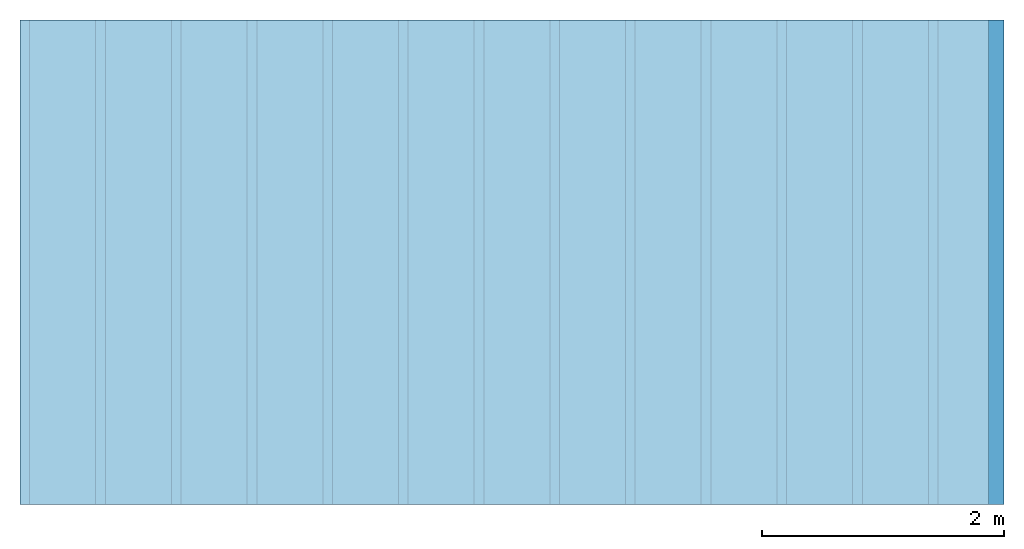
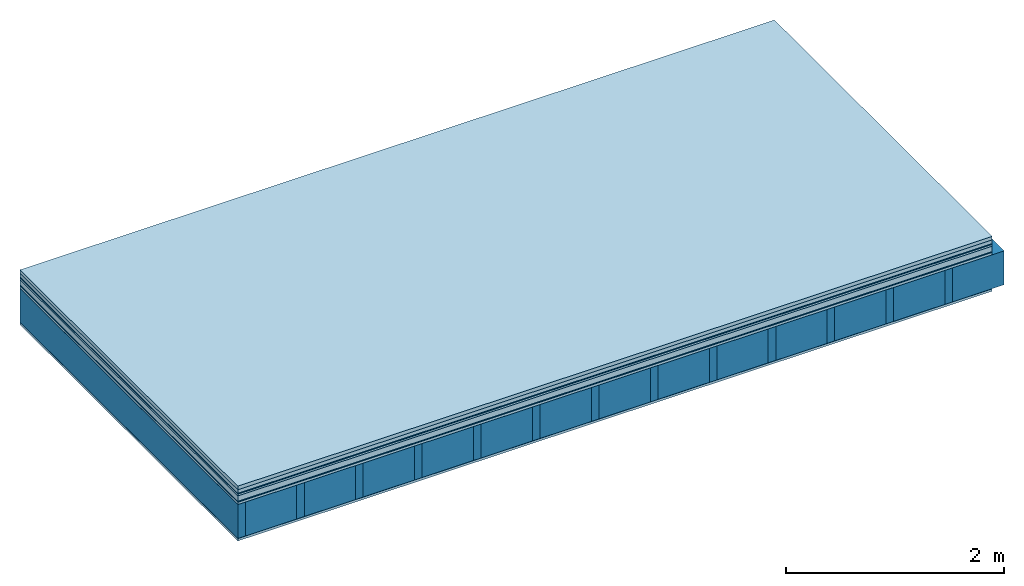
# One storey: 9 plates, 2 members, 1 element without a shape of its own.
"""IFC4 building model written with IfcOpenShell, lengths in metres."""

from ifc_helpers import new_model, si_unit, derived_unit, direction, frame, frame_2d, origin, origin_with_axes, place, context, project, spatial, rectangle, extrude, material, layer, layer_set, type_object, element, aggregate, save


model = new_model("IFC4")

# Units and contexts
plan_context = context("Plan", 3, precision=1e-05, world=origin(), true_north=direction((0.0, 1.0)))
model_context = context("Model", 3, precision=1e-05, world=origin(), true_north=direction((0.0, 1.0)))
ifc_project = project(units=[si_unit("LENGTHUNIT", "METRE"), derived_unit("SOUNDPRESSUREUNIT", [(si_unit("PRESSUREUNIT", "PASCAL", prefix="MICRO"), 0)]), si_unit("ENERGYUNIT", "JOULE", prefix="MEGA"), si_unit("MASSUNIT", "GRAM", prefix="KILO"), derived_unit("THERMALTRANSMITTANCEUNIT", [(si_unit("POWERUNIT", "WATT"), 1), (si_unit("AREAUNIT", "SQUARE_METRE"), -1), (si_unit("THERMODYNAMICTEMPERATUREUNIT", "KELVIN"), -1)]), derived_unit("AREADENSITYUNIT", [(si_unit("MASSUNIT", "GRAM", prefix="KILO"), 1), (si_unit("AREAUNIT", "SQUARE_METRE"), -1)]), derived_unit("USERDEFINED", [(si_unit("ENERGYUNIT", "JOULE", prefix="MEGA"), 1), (si_unit("AREAUNIT", "SQUARE_METRE"), -1)])], contexts=[plan_context, model_context])

# Site, building, storey
site = spatial("IfcSite", under=ifc_project)
building_placement = place(None, origin())
building = spatial("IfcBuilding", under=site, at=building_placement)
storey_placement = place(building_placement, origin())
storey = spatial("IfcBuildingStorey", under=building, at=storey_placement)

# Slab, members, plates
ifc_material_1 = material(Name="Garden plates", Category="02.007")
ifc_layer_1 = layer(ifc_material_1, 0.04, Name="Use and protection layer 3")
ifc_material_2 = material(Name="Gravel 8-16mm", Category="03.011")
ifc_layer_2 = layer(ifc_material_2, 0.04, Name="Use and protection layer 2")
ifc_material_3 = material(Name="Protective layer", Category="09.007")
ifc_layer_3 = layer(ifc_material_3, 0.01, Name="Use and protection layer 1")
ifc_material_4 = material(Name="Bituminous", Category="09.003")
ifc_layer_4 = layer(ifc_material_4, 0.02, Name="Seal")
ifc_material_5 = material(Name="Mineral wool", Category="10.008")
ifc_layer_5 = layer(ifc_material_5, 0.06, Name="Exterior insulation layer 1")
ifc_material_6 = material(Name="Vapor-permeable barrier", Category="09.006")
ifc_layer_6 = layer(ifc_material_6, 0.01, Name="layer / temporary roof")
ifc_material_7 = material(Name="3-layer panels", Category="07.001")
ifc_layer_7 = layer(ifc_material_7, 0.027, Name="above 2nd layer")
ifc_material_8 = material(Name="no composite action")
ifc_layer_8 = layer(ifc_material_8, 0.0, Name="Bond")
ifc_layer_9 = layer(None, 0.38, Name="Support")
ifc_material_9 = material(Name="of the art")
ifc_layer_10 = layer(ifc_material_9, 0.0, Name="Bond")
ifc_material_10 = material(Name="Vapor barrier polyethylene (PE)", Category="09.002")
ifc_layer_11 = layer(ifc_material_10, 0.001, Name="Vapor barrier")
ifc_layer_12 = layer(ifc_material_7, 0.027, Name="Covering below 1st layer")
ifc_layer_set = layer_set([ifc_layer_1, ifc_layer_2, ifc_layer_3, ifc_layer_4, ifc_layer_5, ifc_layer_6, ifc_layer_7, ifc_layer_8, ifc_layer_9, ifc_layer_10, ifc_layer_11, ifc_layer_12])
slab_type = type_object("IfcSlabType", Name="F0105", PredefinedType="NOTDEFINED", material=ifc_layer_set)
slab_placement = place(None, frame((0.0, 0.0, 0.0), z_axis=(0.0, 0.0, -1.0), x_axis=(1.0, 0.0, 0.0)))
slab = element("IfcSlab", 1, at=slab_placement, inside=storey, type_object=slab_type, material=ifc_layer_set, Name="Slab #1")
ifc_material_11 = material()
member_1_placement = place(slab_placement, origin())
member_1 = element("IfcMember", 2, at=member_1_placement, material=ifc_material_11, Name="Support", context=plan_context, shape_type="SweptSolid", body=[
    extrude(rectangle(XDim=0.08, YDim=0.38, at=frame_2d((0.04, 0.19), x_axis=(1.0, 0.0))), frame((0.0, 4.0, 0.207), z_axis=(0.0, -1.0, 0.0), x_axis=(1.0, 0.0, 0.0)), (0.0, 0.0, 1.0), 4.0),
    extrude(rectangle(XDim=0.08, YDim=0.38, at=frame_2d((0.04, 0.19), x_axis=(1.0, 0.0))), frame((0.625, 4.0, 0.207), z_axis=(0.0, -1.0, 0.0), x_axis=(1.0, 0.0, 0.0)), (0.0, 0.0, 1.0), 4.0),
    extrude(rectangle(XDim=0.08, YDim=0.38, at=frame_2d((0.04, 0.19), x_axis=(1.0, 0.0))), frame((1.25, 4.0, 0.207), z_axis=(0.0, -1.0, 0.0), x_axis=(1.0, 0.0, 0.0)), (0.0, 0.0, 1.0), 4.0),
    extrude(rectangle(XDim=0.08, YDim=0.38, at=frame_2d((0.04, 0.19), x_axis=(1.0, 0.0))), frame((1.875, 4.0, 0.207), z_axis=(0.0, -1.0, 0.0), x_axis=(1.0, 0.0, 0.0)), (0.0, 0.0, 1.0), 4.0),
    extrude(rectangle(XDim=0.08, YDim=0.38, at=frame_2d((0.04, 0.19), x_axis=(1.0, 0.0))), frame((2.5, 4.0, 0.207), z_axis=(0.0, -1.0, 0.0), x_axis=(1.0, 0.0, 0.0)), (0.0, 0.0, 1.0), 4.0),
    extrude(rectangle(XDim=0.08, YDim=0.38, at=frame_2d((0.04, 0.19), x_axis=(1.0, 0.0))), frame((3.125, 4.0, 0.207), z_axis=(0.0, -1.0, 0.0), x_axis=(1.0, 0.0, 0.0)), (0.0, 0.0, 1.0), 4.0),
    extrude(rectangle(XDim=0.08, YDim=0.38, at=frame_2d((0.04, 0.19), x_axis=(1.0, 0.0))), frame((3.75, 4.0, 0.207), z_axis=(0.0, -1.0, 0.0), x_axis=(1.0, 0.0, 0.0)), (0.0, 0.0, 1.0), 4.0),
    extrude(rectangle(XDim=0.08, YDim=0.38, at=frame_2d((0.04, 0.19), x_axis=(1.0, 0.0))), frame((4.375, 4.0, 0.207), z_axis=(0.0, -1.0, 0.0), x_axis=(1.0, 0.0, 0.0)), (0.0, 0.0, 1.0), 4.0),
    extrude(rectangle(XDim=0.08, YDim=0.38, at=frame_2d((0.04, 0.19), x_axis=(1.0, 0.0))), frame((5.0, 4.0, 0.207), z_axis=(0.0, -1.0, 0.0), x_axis=(1.0, 0.0, 0.0)), (0.0, 0.0, 1.0), 4.0),
    extrude(rectangle(XDim=0.08, YDim=0.38, at=frame_2d((0.04, 0.19), x_axis=(1.0, 0.0))), frame((5.625, 4.0, 0.207), z_axis=(0.0, -1.0, 0.0), x_axis=(1.0, 0.0, 0.0)), (0.0, 0.0, 1.0), 4.0),
    extrude(rectangle(XDim=0.08, YDim=0.38, at=frame_2d((0.04, 0.19), x_axis=(1.0, 0.0))), frame((6.25, 4.0, 0.207), z_axis=(0.0, -1.0, 0.0), x_axis=(1.0, 0.0, 0.0)), (0.0, 0.0, 1.0), 4.0),
    extrude(rectangle(XDim=0.08, YDim=0.38, at=frame_2d((0.04, 0.19), x_axis=(1.0, 0.0))), frame((6.875, 4.0, 0.207), z_axis=(0.0, -1.0, 0.0), x_axis=(1.0, 0.0, 0.0)), (0.0, 0.0, 1.0), 4.0),
    extrude(rectangle(XDim=0.08, YDim=0.38, at=frame_2d((0.04, 0.19), x_axis=(1.0, 0.0))), frame((7.5, 4.0, 0.207), z_axis=(0.0, -1.0, 0.0), x_axis=(1.0, 0.0, 0.0)), (0.0, 0.0, 1.0), 4.0),
])
ifc_material_12 = material()
member_2_placement = place(slab_placement, origin())
member_2 = element("IfcMember", 3, at=member_2_placement, material=ifc_material_12, Name="Cavity", context=plan_context, shape_type="SweptSolid", body=[
    extrude(rectangle(XDim=0.545, YDim=0.38, at=frame_2d((0.2725, 0.19), x_axis=(1.0, 0.0))), frame((0.08, 4.0, 0.207), z_axis=(0.0, -1.0, 0.0), x_axis=(1.0, 0.0, 0.0)), (0.0, 0.0, 1.0), 4.0),
    extrude(rectangle(XDim=0.545, YDim=0.38, at=frame_2d((0.2725, 0.19), x_axis=(1.0, 0.0))), frame((0.705, 4.0, 0.207), z_axis=(0.0, -1.0, 0.0), x_axis=(1.0, 0.0, 0.0)), (0.0, 0.0, 1.0), 4.0),
    extrude(rectangle(XDim=0.545, YDim=0.38, at=frame_2d((0.2725, 0.19), x_axis=(1.0, 0.0))), frame((1.33, 4.0, 0.207), z_axis=(0.0, -1.0, 0.0), x_axis=(1.0, 0.0, 0.0)), (0.0, 0.0, 1.0), 4.0),
    extrude(rectangle(XDim=0.545, YDim=0.38, at=frame_2d((0.2725, 0.19), x_axis=(1.0, 0.0))), frame((1.955, 4.0, 0.207), z_axis=(0.0, -1.0, 0.0), x_axis=(1.0, 0.0, 0.0)), (0.0, 0.0, 1.0), 4.0),
    extrude(rectangle(XDim=0.545, YDim=0.38, at=frame_2d((0.2725, 0.19), x_axis=(1.0, 0.0))), frame((2.58, 4.0, 0.207), z_axis=(0.0, -1.0, 0.0), x_axis=(1.0, 0.0, 0.0)), (0.0, 0.0, 1.0), 4.0),
    extrude(rectangle(XDim=0.545, YDim=0.38, at=frame_2d((0.2725, 0.19), x_axis=(1.0, 0.0))), frame((3.205, 4.0, 0.207), z_axis=(0.0, -1.0, 0.0), x_axis=(1.0, 0.0, 0.0)), (0.0, 0.0, 1.0), 4.0),
    extrude(rectangle(XDim=0.545, YDim=0.38, at=frame_2d((0.2725, 0.19), x_axis=(1.0, 0.0))), frame((3.83, 4.0, 0.207), z_axis=(0.0, -1.0, 0.0), x_axis=(1.0, 0.0, 0.0)), (0.0, 0.0, 1.0), 4.0),
    extrude(rectangle(XDim=0.545, YDim=0.38, at=frame_2d((0.2725, 0.19), x_axis=(1.0, 0.0))), frame((4.455, 4.0, 0.207), z_axis=(0.0, -1.0, 0.0), x_axis=(1.0, 0.0, 0.0)), (0.0, 0.0, 1.0), 4.0),
    extrude(rectangle(XDim=0.545, YDim=0.38, at=frame_2d((0.2725, 0.19), x_axis=(1.0, 0.0))), frame((5.08, 4.0, 0.207), z_axis=(0.0, -1.0, 0.0), x_axis=(1.0, 0.0, 0.0)), (0.0, 0.0, 1.0), 4.0),
    extrude(rectangle(XDim=0.545, YDim=0.38, at=frame_2d((0.2725, 0.19), x_axis=(1.0, 0.0))), frame((5.705, 4.0, 0.207), z_axis=(0.0, -1.0, 0.0), x_axis=(1.0, 0.0, 0.0)), (0.0, 0.0, 1.0), 4.0),
    extrude(rectangle(XDim=0.545, YDim=0.38, at=frame_2d((0.2725, 0.19), x_axis=(1.0, 0.0))), frame((6.33, 4.0, 0.207), z_axis=(0.0, -1.0, 0.0), x_axis=(1.0, 0.0, 0.0)), (0.0, 0.0, 1.0), 4.0),
    extrude(rectangle(XDim=0.545, YDim=0.38, at=frame_2d((0.2725, 0.19), x_axis=(1.0, 0.0))), frame((6.955, 4.0, 0.207), z_axis=(0.0, -1.0, 0.0), x_axis=(1.0, 0.0, 0.0)), (0.0, 0.0, 1.0), 4.0),
    extrude(rectangle(XDim=0.545, YDim=0.38, at=frame_2d((0.2725, 0.19), x_axis=(1.0, 0.0))), frame((7.58, 4.0, 0.207), z_axis=(0.0, -1.0, 0.0), x_axis=(1.0, 0.0, 0.0)), (0.0, 0.0, 1.0), 4.0),
])
plate_1_placement = place(slab_placement, origin())
plate_1 = element("IfcPlate", 4, at=plate_1_placement, material=ifc_material_1, Name="Use and protection layer 3", context=plan_context, shape_type="SweptSolid", body=[
    extrude(rectangle(XDim=8.0, YDim=4.0, at=frame_2d((4.0, 2.0), x_axis=(1.0, 0.0))), origin_with_axes(), (0.0, 0.0, 1.0), 0.04),
])
plate_2_placement = place(slab_placement, origin())
plate_2 = element("IfcPlate", 5, at=plate_2_placement, material=ifc_material_2, Name="Use and protection layer 2", context=plan_context, shape_type="SweptSolid", body=[
    extrude(rectangle(XDim=8.0, YDim=4.0, at=frame_2d((4.0, 2.0), x_axis=(1.0, 0.0))), frame((0.0, 0.0, 0.04), z_axis=(0.0, 0.0, 1.0), x_axis=(1.0, 0.0, 0.0)), (0.0, 0.0, 1.0), 0.04),
])
plate_3_placement = place(slab_placement, origin())
plate_3 = element("IfcPlate", 6, at=plate_3_placement, material=ifc_material_3, Name="Use and protection layer 1", context=plan_context, shape_type="SweptSolid", body=[
    extrude(rectangle(XDim=8.0, YDim=4.0, at=frame_2d((4.0, 2.0), x_axis=(1.0, 0.0))), frame((0.0, 0.0, 0.08), z_axis=(0.0, 0.0, 1.0), x_axis=(1.0, 0.0, 0.0)), (0.0, 0.0, 1.0), 0.01),
])
plate_4_placement = place(slab_placement, origin())
plate_4 = element("IfcPlate", 7, at=plate_4_placement, material=ifc_material_4, Name="Seal", context=plan_context, shape_type="SweptSolid", body=[
    extrude(rectangle(XDim=8.0, YDim=4.0, at=frame_2d((4.0, 2.0), x_axis=(1.0, 0.0))), frame((0.0, 0.0, 0.09), z_axis=(0.0, 0.0, 1.0), x_axis=(1.0, 0.0, 0.0)), (0.0, 0.0, 1.0), 0.02),
])
plate_5_placement = place(slab_placement, origin())
plate_5 = element("IfcPlate", 8, at=plate_5_placement, material=ifc_material_5, Name="Exterior insulation layer 1", context=plan_context, shape_type="SweptSolid", body=[
    extrude(rectangle(XDim=8.0, YDim=4.0, at=frame_2d((4.0, 2.0), x_axis=(1.0, 0.0))), frame((0.0, 0.0, 0.11), z_axis=(0.0, 0.0, 1.0), x_axis=(1.0, 0.0, 0.0)), (0.0, 0.0, 1.0), 0.06),
])
plate_6_placement = place(slab_placement, origin())
plate_6 = element("IfcPlate", 9, at=plate_6_placement, material=ifc_material_6, Name="layer / temporary roof", context=plan_context, shape_type="SweptSolid", body=[
    extrude(rectangle(XDim=8.0, YDim=4.0, at=frame_2d((4.0, 2.0), x_axis=(1.0, 0.0))), frame((0.0, 0.0, 0.17), z_axis=(0.0, 0.0, 1.0), x_axis=(1.0, 0.0, 0.0)), (0.0, 0.0, 1.0), 0.01),
])
plate_7_placement = place(slab_placement, origin())
plate_7 = element("IfcPlate", 10, at=plate_7_placement, material=ifc_material_7, Name="above 2nd layer", context=plan_context, shape_type="SweptSolid", body=[
    extrude(rectangle(XDim=8.0, YDim=4.0, at=frame_2d((4.0, 2.0), x_axis=(1.0, 0.0))), frame((0.0, 0.0, 0.18), z_axis=(0.0, 0.0, 1.0), x_axis=(1.0, 0.0, 0.0)), (0.0, 0.0, 1.0), 0.027),
])
plate_8_placement = place(slab_placement, origin())
plate_8 = element("IfcPlate", 11, at=plate_8_placement, material=ifc_material_10, Name="Vapor barrier", context=plan_context, shape_type="SweptSolid", body=[
    extrude(rectangle(XDim=8.0, YDim=4.0, at=frame_2d((4.0, 2.0), x_axis=(1.0, 0.0))), frame((0.0, 0.0, 0.587), z_axis=(0.0, 0.0, 1.0), x_axis=(1.0, 0.0, 0.0)), (0.0, 0.0, 1.0), 0.001),
])
plate_9_placement = place(slab_placement, origin())
plate_9 = element("IfcPlate", 12, at=plate_9_placement, material=ifc_material_7, Name="Covering below 1st layer", context=plan_context, shape_type="SweptSolid", body=[
    extrude(rectangle(XDim=8.0, YDim=4.0, at=frame_2d((4.0, 2.0), x_axis=(1.0, 0.0))), frame((0.0, 0.0, 0.588), z_axis=(0.0, 0.0, 1.0), x_axis=(1.0, 0.0, 0.0)), (0.0, 0.0, 1.0), 0.027),
])
aggregate(slab, [plate_1, plate_2, plate_3, plate_4, plate_5, plate_6, plate_7, member_1, member_2, plate_8, plate_9])

save(model, "model.ifc")
